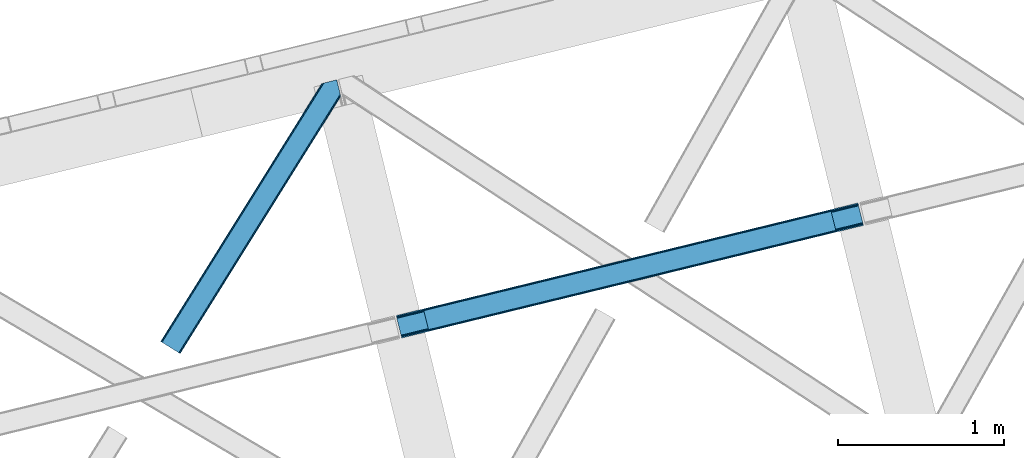
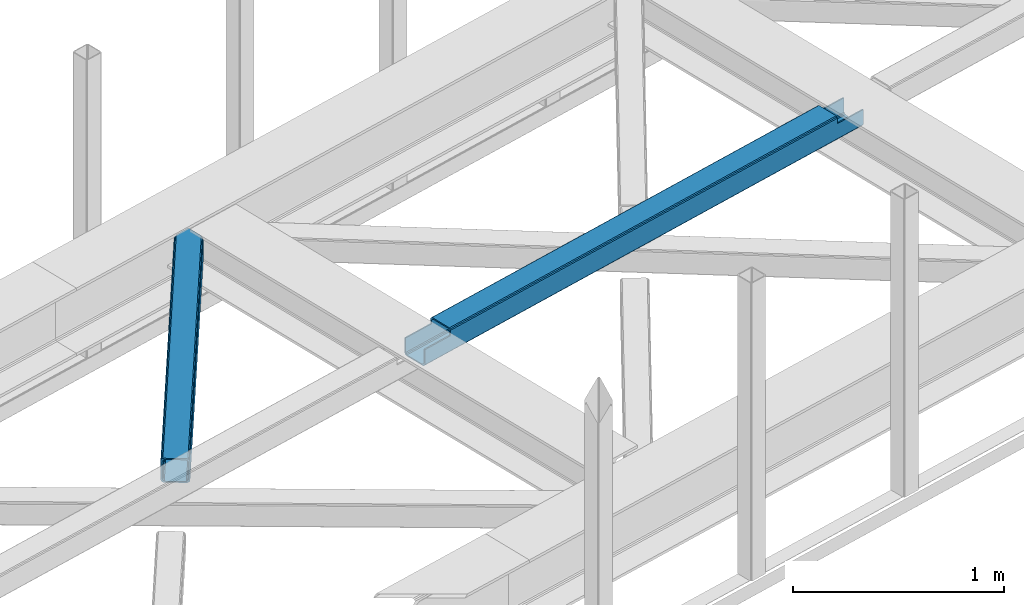
# One storey, part 53 of 67: 1 beam, 1 member.
"""IFC4 building model written with IfcOpenShell, lengths in millimetres."""

import ifcopenshell
import ifcopenshell.guid

model = None  # the IFC model being written
_history = None  # IfcOwnerHistory: only IFC2X3 demands one
_inside = {}  # id of a spatial element -> (the spatial element, [elements in it])
_under = {}  # id of a project, library or spatial element -> (it, [spatial elements below it])
_declared = {}  # id of a project -> (the project, [libraries it declares])
_typed = {}  # id of a type object -> (the type object, [elements of that type])
_made_of = {}  # id of a material, layer set ... -> (it, [elements and type objects made of it])


def new_model(schema):
    """Start an empty IFC model of exactly this schema.

    Asked for "IFC4X3", IfcOpenShell would pick the latest addendum, in which some entities
    have other attributes; the version numbers below select the first issue.
    IFC2X3 requires an IfcOwnerHistory on every rooted entity: one is made here for all.
    """
    global model, _history
    if schema == "IFC4X3":
        model = ifcopenshell.file(schema_version=(4, 3, 0, 0))
    else:
        model = ifcopenshell.file(schema=schema)
    _inside.clear()
    _under.clear()
    _declared.clear()
    _typed.clear()
    _made_of.clear()
    _history = None
    if model.schema == "IFC2X3":
        org = make("IfcOrganization", Name="unknown")
        user = make(
            "IfcPersonAndOrganization",
            ThePerson=make("IfcPerson", FamilyName="unknown"),
            TheOrganization=org,
        )
        app = make(
            "IfcApplication",
            ApplicationDeveloper=org,
            Version="unknown",
            ApplicationFullName="unknown",
            ApplicationIdentifier="unknown",
        )
        _history = make(
            "IfcOwnerHistory",
            OwningUser=user,
            OwningApplication=app,
            ChangeAction="ADDED",
            CreationDate=0,
        )
    return model


def make(cls, **values):
    """One entity of the class cls with the attributes given. An attribute that is None is left unset."""
    return model.create_entity(
        cls, **{name: value for name, value in values.items() if value is not None}
    )


def entity(cls, *values):
    """Any entity or typed value of the class cls, its attributes in the order of the schema. None: left unset."""
    e = model.create_entity(cls)
    for i, value in enumerate(values):
        if value is not None:
            e[i] = value
    return e


def rooted(cls, **values):
    """An entity with a GlobalId (a new one), such as an element, a storey or a relation."""
    return make(cls, GlobalId=ifcopenshell.guid.new(), OwnerHistory=_history, **values)


def si_unit(unit_type, name, prefix=None):
    """IfcSIUnit, for example si_unit("LENGTHUNIT", "METRE", prefix="MILLI")."""
    return make("IfcSIUnit", UnitType=unit_type, Prefix=prefix, Name=name)


def converted_unit(unit_type, name, factor, base, dimensions=None, offset=None):
    """IfcConversionBasedUnit, such as the inch: factor (a typed value) times the base unit."""
    return make(
        "IfcConversionBasedUnit"
        if offset is None
        else "IfcConversionBasedUnitWithOffset",
        ConversionOffset=offset,
        Dimensions=None
        if dimensions is None
        else entity("IfcDimensionalExponents", *dimensions),
        UnitType=unit_type,
        Name=name,
        ConversionFactor=make(
            "IfcMeasureWithUnit", ValueComponent=factor, UnitComponent=base
        ),
    )


def derived_unit(unit_type, elements):
    """IfcDerivedUnit: a product of units, each with its exponent."""
    return make(
        "IfcDerivedUnit",
        Elements=[
            make("IfcDerivedUnitElement", Unit=unit, Exponent=power)
            for unit, power in elements
        ],
        UnitType=unit_type,
    )


def assignment(units):
    """IfcUnitAssignment: the units of a project."""
    return None if units is None else make("IfcUnitAssignment", Units=units)


def point(xyz):
    """IfcCartesianPoint."""
    return None if xyz is None else make("IfcCartesianPoint", Coordinates=xyz)


def direction(xyz):
    """IfcDirection."""
    return None if xyz is None else make("IfcDirection", DirectionRatios=xyz)


def frame(location, z_axis=None, x_axis=None):
    """IfcAxis2Placement3D, a coordinate frame: its origin and axes. An axis left out is left unset."""
    return make(
        "IfcAxis2Placement3D",
        Location=point(location),
        Axis=direction(z_axis),
        RefDirection=direction(x_axis),
    )


def origin():
    """The frame at (0, 0, 0) with its axes left unset."""
    return frame((0.0, 0.0, 0.0))


def place(relative_to, where):
    """IfcLocalPlacement: puts the frame where relative to a parent placement (None: the world)."""
    return make(
        "IfcLocalPlacement", PlacementRelTo=relative_to, RelativePlacement=where
    )


def context(
    kind, dimensions, precision=None, world=None, true_north=None, identifier=None
):
    """IfcGeometricRepresentationContext, for example the 3D "Model" context."""
    return make(
        "IfcGeometricRepresentationContext",
        ContextIdentifier=identifier,
        ContextType=kind,
        CoordinateSpaceDimension=dimensions,
        Precision=precision,
        WorldCoordinateSystem=world,
        TrueNorth=true_north,
    )


def subcontext(parent, identifier, kind, view, scale=None):
    """IfcGeometricRepresentationSubContext, for example "Body" below "Model"."""
    return make(
        "IfcGeometricRepresentationSubContext",
        ContextIdentifier=identifier,
        ContextType=kind,
        ParentContext=parent,
        TargetScale=scale,
        TargetView=view,
    )


def project(units=None, contexts=None):
    """IfcProject with its units and contexts."""
    return rooted(
        "IfcProject",
        Name="project",
        RepresentationContexts=contexts,
        UnitsInContext=assignment(units),
    )


def spatial(cls, under=None, at=None, **own):
    """A site, building, storey or space (cls), placed at a placement, below another one or the project."""
    s = rooted(cls, ObjectPlacement=at, **own)
    if under is not None:
        _under.setdefault(under.id(), (under, []))[1].append(s)
    return s


def point_list(points):
    """IfcCartesianPointList2D or 3D."""
    cls = (
        "IfcCartesianPointList2D" if len(points[0]) == 2 else "IfcCartesianPointList3D"
    )
    return make(cls, CoordList=points)


def triangles(points, corners, closed=None, point_numbers=None):
    """IfcTriangulatedFaceSet: each triangle names its three corners, points numbered from 1."""
    return make(
        "IfcTriangulatedFaceSet",
        Coordinates=point_list(points),
        Closed=closed,
        CoordIndex=corners,
        PnIndex=point_numbers,
    )


def polygons(points, faces, closed=None, point_numbers=None):
    """IfcPolygonalFaceSet: a face is its outer loop, then its inner loops; points numbered from 1."""
    made = []
    for loops in faces:
        if len(loops) == 1:
            made.append(make("IfcIndexedPolygonalFace", CoordIndex=loops[0]))
        else:
            made.append(
                make(
                    "IfcIndexedPolygonalFaceWithVoids",
                    CoordIndex=loops[0],
                    InnerCoordIndices=loops[1:],
                )
            )
    return make(
        "IfcPolygonalFaceSet",
        Coordinates=point_list(points),
        Closed=closed,
        Faces=made,
        PnIndex=point_numbers,
    )


def shape(context_of_items, identifier, shape_type, items):
    """IfcShapeRepresentation: the items that make up one representation, for example the "Body"."""
    return make(
        "IfcShapeRepresentation",
        ContextOfItems=context_of_items,
        RepresentationIdentifier=identifier,
        RepresentationType=shape_type,
        Items=items,
    )


def material(Name=None, Category=None):
    """IfcMaterial."""
    return make("IfcMaterial", Name=Name, Category=Category)


def made_of(thing, what):
    """Note that an element or type object is made of a material, layer set ...; save() writes the relation."""
    if what is not None:
        _made_of.setdefault(what.id(), (what, []))[1].append(thing)
    return thing


def type_object(cls, material=None, **own):
    """A type object (cls), such as IfcWallType, which elements share."""
    return made_of(rooted(cls, **own), material)


def element(
    cls,
    number,
    at=None,
    inside=None,
    cuts=None,
    type_object=None,
    material=None,
    context=None,
    identifier="Body",
    shape_type=None,
    held_by="IfcProductDefinitionShape",
    body=None,
    shapes=None,
    **own,
):
    """One element of the class cls, such as IfcWall. Its Tag is "e" and its number.

    at: its placement. inside: the storey or other place that contains it. cuts: it is an
    opening in that element (IfcRelVoidsElement). A single representation is given by context,
    identifier, shape_type and body (its items); several are given by shapes. held_by: the class
    of the entity that holds the representations. save() writes the other relations.
    """
    e = rooted(cls, Tag="e%d" % number, ObjectPlacement=at, **own)
    if body is not None:
        shapes = [shape(context, identifier, shape_type, body)]
    if shapes is not None:
        e.Representation = make(held_by, Representations=shapes)
    if inside is not None:
        _inside.setdefault(inside.id(), (inside, []))[1].append(e)
    if cuts is not None:
        rooted(
            "IfcRelVoidsElement", RelatingBuildingElement=cuts, RelatedOpeningElement=e
        )
    if type_object is not None:
        _typed.setdefault(type_object.id(), (type_object, []))[1].append(e)
    return made_of(e, material)


def aggregate(whole, parts):
    """IfcRelAggregates: a whole, such as a stair, and the parts it consists of."""
    return rooted("IfcRelAggregates", RelatingObject=whole, RelatedObjects=parts)


def save(model, path):
    """Write the relations noted so far, then the file.

    IfcRelAggregates (storeys below a building ...), IfcRelContainedInSpatialStructure (elements
    in a storey), IfcRelDefinesByType, IfcRelAssociatesMaterial and IfcRelDeclares: one each for
    every whole, place, type object, material and project.
    """
    for whole, parts in _under.values():
        aggregate(whole, parts)
    for where, things in _inside.values():
        rooted(
            "IfcRelContainedInSpatialStructure",
            RelatedElements=things,
            RelatingStructure=where,
        )
    for kind, things in _typed.values():
        rooted("IfcRelDefinesByType", RelatedObjects=things, RelatingType=kind)
    for what, things in _made_of.values():
        rooted("IfcRelAssociatesMaterial", RelatedObjects=things, RelatingMaterial=what)
    for by, libraries in _declared.values():
        rooted("IfcRelDeclares", RelatingContext=by, RelatedDefinitions=libraries)
    model.write(path)


model = new_model("IFC4")

# Units and contexts
model_context = context("Model", 3, precision=0.01, world=origin(), true_north=direction((6.12303176911189e-17, 1.0)))
plan_context = context("Plan", 3, precision=0.01, world=origin(), true_north=direction((6.12303176911189e-17, 1.0)))
body_context = subcontext(model_context, "Body", "Model", "MODEL_VIEW")
ifc_project = project(units=[si_unit("LENGTHUNIT", "METRE", prefix="MILLI"), si_unit("AREAUNIT", "SQUARE_METRE"), si_unit("VOLUMEUNIT", "CUBIC_METRE"), converted_unit("PLANEANGLEUNIT", "DEGREE", entity("IfcRatioMeasure", 0.0174532925199433), si_unit("PLANEANGLEUNIT", "RADIAN"), dimensions=[0, 0, 0, 0, 0, 0, 0]), si_unit("MASSUNIT", "GRAM", prefix="KILO"), derived_unit("MASSDENSITYUNIT", [(si_unit("MASSUNIT", "GRAM", prefix="KILO"), 1), (si_unit("LENGTHUNIT", "METRE"), -3)]), derived_unit("MOMENTOFINERTIAUNIT", [(si_unit("LENGTHUNIT", "METRE"), 4)]), si_unit("TIMEUNIT", "SECOND"), si_unit("FREQUENCYUNIT", "HERTZ"), si_unit("THERMODYNAMICTEMPERATUREUNIT", "DEGREE_CELSIUS"), derived_unit("THERMALTRANSMITTANCEUNIT", [(si_unit("MASSUNIT", "GRAM", prefix="KILO"), 1), (si_unit("THERMODYNAMICTEMPERATUREUNIT", "KELVIN"), -1), (si_unit("TIMEUNIT", "SECOND"), -3)]), derived_unit("VOLUMETRICFLOWRATEUNIT", [(si_unit("LENGTHUNIT", "METRE"), 3), (si_unit("TIMEUNIT", "SECOND"), -1)]), derived_unit("MASSFLOWRATEUNIT", [(si_unit("MASSUNIT", "GRAM", prefix="KILO"), 1), (si_unit("TIMEUNIT", "SECOND"), -1)]), derived_unit("ROTATIONALFREQUENCYUNIT", [(si_unit("TIMEUNIT", "SECOND"), -1)]), si_unit("ELECTRICCURRENTUNIT", "AMPERE"), si_unit("ELECTRICVOLTAGEUNIT", "VOLT"), si_unit("POWERUNIT", "WATT"), si_unit("FORCEUNIT", "NEWTON", prefix="KILO"), si_unit("ILLUMINANCEUNIT", "LUX"), si_unit("LUMINOUSFLUXUNIT", "LUMEN"), si_unit("LUMINOUSINTENSITYUNIT", "CANDELA"), derived_unit("USERDEFINED", [(si_unit("MASSUNIT", "GRAM", prefix="KILO"), -1), (si_unit("LENGTHUNIT", "METRE"), -2), (si_unit("TIMEUNIT", "SECOND"), 3), (si_unit("LUMINOUSFLUXUNIT", "LUMEN"), 1)]), derived_unit("LINEARVELOCITYUNIT", [(si_unit("LENGTHUNIT", "METRE"), 1), (si_unit("TIMEUNIT", "SECOND"), -1)]), si_unit("PRESSUREUNIT", "PASCAL"), derived_unit("USERDEFINED", [(si_unit("LENGTHUNIT", "METRE"), -2), (si_unit("MASSUNIT", "GRAM", prefix="KILO"), 1), (si_unit("TIMEUNIT", "SECOND"), -2)]), derived_unit("LINEARFORCEUNIT", [(si_unit("MASSUNIT", "GRAM", prefix="KILO"), 1), (si_unit("LENGTHUNIT", "METRE"), 1), (si_unit("TIMEUNIT", "SECOND"), -2), (si_unit("LENGTHUNIT", "METRE"), -1)]), derived_unit("PLANARFORCEUNIT", [(si_unit("MASSUNIT", "GRAM", prefix="KILO"), 1), (si_unit("LENGTHUNIT", "METRE"), 1), (si_unit("TIMEUNIT", "SECOND"), -2), (si_unit("LENGTHUNIT", "METRE"), -2)])], contexts=[model_context, plan_context])

# Site, building, storey
site_placement = place(None, origin())
site = spatial("IfcSite", under=ifc_project, at=site_placement, CompositionType="ELEMENT")
building_placement = place(site_placement, origin())
building = spatial("IfcBuilding", under=site, at=building_placement, CompositionType="ELEMENT")
storey_placement = place(building_placement, frame((0.0, 0.0, 19800.0)))
storey = spatial("IfcBuildingStorey", under=building, at=storey_placement, CompositionType="ELEMENT", Elevation=19800.0)

# Beam
ifc_material = material(Name="Metal painted (White)")
beam_type = type_object("IfcBeamType", PredefinedType="BEAM")
beam_placement = place(storey_placement, frame((-11387.6664758472, 16364.0782857398, 3967.02022389142)))
element("IfcBeam", 1, at=beam_placement, inside=storey, type_object=beam_type, material=ifc_material, ObjectType="Steel Beam", PredefinedType="BEAM", context=body_context, shape_type="Tessellation", body=[
    polygons([(31.1823923917571, 8.09507685196108, 17.8030399336114), (31.4978703677273, 6.80086440699434, 24.4999999999988), (2817.90917311746, 686.018099103278, 24.4999999999988), (2817.59369514149, 687.312311548247, 17.8030399336114), (30.2839871259056, 11.7806820741864, 12.1256313292298), (2816.69528987564, 690.997916770472, 12.1256313292298), (28.9394286278213, 17.2965800886753, 8.33210818105214), (2815.35073137756, 696.513814784959, 8.33210818105214), (27.3534137403861, 23.8030254244661, 7.00000000000274), (2813.76471649012, 703.020260120752, 7.00000000000274), (4.21622439083043, 118.720708051134, 8.33210818105214), (5.80223927826556, 112.214262715343, 7.00000000000274), (2792.213542028, 791.431497411626, 7.00000000000274), (2790.62752714057, 797.937942747419, 8.33210818105214), (2.87166589274824, 124.236606065618, 12.1256313292342), (2789.28296864248, 803.453840761904, 12.1256313292342), (1.9732606268946, 127.922211287848, 17.8030399336114), (2788.38456337663, 807.139445984131, 17.8030399336114), (1.65778265094818, 129.216423732819, 24.4999999999988), (2788.06908540067, 808.433658429104, 24.4999999999988), (33.1556530186734, 6.49720277579036e-12, 17.5000000000004), (33.1556530186734, 6.49720277579036e-12, 99.499999999999), (31.4978703677403, 6.80086440699434, 99.499999999999), (1.65778265095251, 129.216423732821, 99.499999999999), (2.38230768445646e-11, 136.017288139815, 99.499999999999), (2.59888111031614e-11, 136.017288139815, 17.5000000000004), (0.315477975985408, 134.723075694844, 10.803039933613), (1.21388324183688, 131.037470472619, 5.12563132923143), (2.55844173992124, 125.52157245813, 1.33210818105373), (4.14445662735637, 119.015127122339, 0.0), (29.011196391343, 17.0021610174826, 0.0), (30.5972112787781, 10.4957156816896, 1.33210818105373), (31.9417697768603, 4.97981766720068, 5.12563132923576), (32.8401750427139, 1.29421244497757, 10.803039933613), (2786.41130274975, 815.234522836097, 17.5000000000004), (2786.41130274974, 815.234522836097, 99.499999999999), (2788.06908540068, 808.433658429104, 99.499999999999), (2817.90917311746, 686.01809910328, 99.499999999999), (2819.56695576839, 679.217234696288, 99.499999999999), (2819.5669557684, 679.217234696288, 17.5000000000004), (2819.25147779244, 680.511447141259, 10.803039933613), (2818.35307252658, 684.197052363484, 5.12563132923576), (2817.0085140285, 689.712950377973, 1.33210818105373), (2815.42249914106, 696.219395713764, 0.0), (2790.55575937708, 798.23236181862, 0.0), (2788.96974448964, 804.738807154413, 1.33210818105373), (2787.62518599156, 810.254705168902, 5.12563132923143), (2786.72678072571, 813.940310391125, 10.803039933613), (2653.72536552979, 645.996559503588, 115.5000123926), (2653.78173361466, 646.010298722204, 100.117303289864), (2654.68842734968, 646.231315480896, 99.499999999999), (194.718606580794, 46.5876811586757, 99.5063429816656), (195.631369831915, 46.810141494503, 100.117301735448), (195.690168193622, 46.824474122359, 115.5), (2656.34621000061, 639.430451073908, 99.499999999999), (2655.43964990836, 639.209466900397, 100.117303484932), (2655.38006714068, 639.194943868054, 122.500007895425), (197.345360928049, 40.0229783796023, 122.500002534479), (197.338587096739, 40.0213271441479, 100.500009163303), (196.748205195722, 39.8773799905087, 99.5697919021647), (2624.84834918759, 768.646841677419, 99.5063429816656), (2623.93924032811, 768.4252715147, 100.117299778624), (2623.88287224324, 768.411532296082, 115.50000888136), (165.850080476841, 169.240033448183, 115.5), (165.84046220334, 169.237688832046, 100.50000941238), (165.250325295035, 169.093836777333, 99.5761204674868), (2622.81875057266, 775.357142845586, 99.5697919021647), (163.220745767765, 175.804071762184, 99.499999999999), (164.133244938514, 176.026503182399, 100.117301984524), (164.18943998763, 176.04020120897, 122.500002796667), (2622.22174126673, 775.211580304167, 122.500003994045), (2622.23184455557, 775.214043718734, 100.500018741102), (2622.53385542111, 773.916547681999, 129.196959150505), (2623.4271909467, 770.229706340309, 134.874360354937), (2624.76848195077, 764.7130116355, 138.667878733795), (2626.35352903677, 758.206330327425, 139.999985502214), (2651.2242780837, 656.194341778115, 139.999991354279), (2652.81177220129, 649.688257112712, 138.667885332354), (2654.16003176172, 644.173261502483, 134.874367586349), (2655.06379646893, 640.488963035532, 129.196966804773), (2653.41217589809, 647.2913298996, 122.196975799125), (2652.50841119088, 650.975628366557, 127.874376580702), (2651.16015163044, 656.490623976784, 131.667894326702), (2649.57265751286, 662.996708642187, 133.000000348631), (2628.01800833885, 751.407098718257, 132.999995276841), (2626.43296125285, 757.913780026333, 131.667888508414), (2625.09167024878, 763.43047473114, 127.874370129564), (2624.19833472319, 767.117316072832, 122.196968925133), (164.878528418698, 169.003207355194, 99.499999999999), (193.131726453727, 57.3201898040399, 131.667891818946), (191.545711566292, 63.8266351398329, 133.0), (194.476284951809, 51.804291789551, 127.874368670764), (195.374690217663, 48.1186865673279, 122.196960066391), (169.994537104169, 152.237872430707, 133.0), (166.165558452801, 167.945821003215, 122.196960066391), (167.063963718652, 164.260215780991, 127.874368670764), (168.408522216736, 158.744317766502, 131.667891818946), (197.031411944073, 41.3175635421181, 129.196961104604), (196.136488323068, 45.0040174739024, 134.874366301861), (194.794244157317, 50.5204796458773, 138.667887185257), (193.209023953586, 57.0271186992037, 139.999994588639), (168.341882306943, 159.039986838394, 139.999994981919), (166.755021471191, 165.546225960038, 138.667887628704), (165.408105180735, 171.061549222932, 134.874366787843), (164.506189230969, 174.746298656828, 129.196961619)], [[[1, 2, 3, 4]], [[5, 1, 4, 6]], [[7, 5, 6, 8]], [[9, 7, 8, 10]], [[11, 12, 13, 14]], [[15, 11, 14, 16]], [[17, 15, 16, 18]], [[19, 17, 18, 20]], [[12, 9, 10, 13]], [[21, 22, 23, 2, 1, 5, 7, 9, 12, 11, 15, 17, 19, 24, 25, 26, 27, 28, 29, 30, 31, 32, 33, 34]], [[35, 36, 37, 20, 18, 16, 14, 13, 10, 8, 6, 4, 3, 38, 39, 40, 41, 42, 43, 44, 45, 46, 47, 48]], [[49, 50, 51, 38, 3, 2, 23, 52, 53, 54]], [[55, 39, 38, 51]], [[39, 55, 56, 57, 58, 59, 60, 22, 21, 40]], [[32, 31, 44, 43]], [[33, 32, 43, 42]], [[34, 33, 42, 41]], [[21, 34, 41, 40]], [[31, 30, 45, 44]], [[27, 26, 35, 48]], [[28, 27, 48, 47]], [[29, 28, 47, 46]], [[30, 29, 46, 45]], [[20, 37, 61, 62, 63, 64, 65, 66, 24, 19]], [[67, 36, 35, 26, 25, 68, 69, 70, 71, 72]], [[36, 67, 61, 37]], [[72, 71, 73, 74, 75, 76, 77, 78, 79, 80, 57, 56, 50, 49, 81, 82, 83, 84, 85, 86, 87, 88, 63, 62]], [[60, 52, 23, 22]], [[25, 24, 89, 68]], [[90, 91, 84, 83]], [[92, 90, 83, 82]], [[93, 92, 82, 81]], [[54, 93, 81, 49]], [[94, 85, 84, 91]], [[95, 64, 63, 88]], [[96, 95, 88, 87]], [[97, 96, 87, 86]], [[94, 97, 86, 85]], [[65, 64, 95, 96, 97, 94, 91, 90, 92, 93, 54, 53, 59, 58, 98, 99, 100, 101, 102, 103, 104, 105, 70, 69]], [[98, 58, 57, 80]], [[99, 98, 80, 79]], [[100, 99, 79, 78]], [[101, 100, 78, 77]], [[77, 76, 102, 101]], [[103, 102, 76, 75]], [[104, 103, 75, 74]], [[105, 104, 74, 73]], [[70, 105, 73, 71]]], closed=False),
])

# Member
member_type = type_object("IfcMemberType", PredefinedType="BRACE")
member_placement = place(storey_placement, frame((-12809.6402069092, 16269.3394958496, 3822.99993896484)))
element("IfcMember", 2, at=member_placement, inside=storey, type_object=member_type, ObjectType="Steel Horizontal Brace", PredefinedType="BRACE", context=body_context, shape_type="Tessellation", body=[
    triangles([(933.019793701173, 1535.69114685059, 0.0), (967.779299926759, 1393.09054870606, 0.0), (14.8479309082031, 64.8692962646492, 0.0), (103.918075561523, 9.26687622070313, 0.0), (928.802609252929, 1552.99009094238, 5.49966430664063), (928.943298339844, 1552.41570739746, 5.208984375), (930.802487182616, 1544.78594055176, 1.33247680664135), (971.996484375, 1375.79160461426, 5.49966430664063), (971.856958007813, 1376.36598815918, 5.208984375), (969.996606445313, 1383.99575500488, 1.33247680664135), (972.211587524414, 1375.53696899414, 5.8531311035149), (972.422039794921, 1375.28233337402, 6.20659790039281), (928.915393066407, 1553.56912536621, 5.74383544921875), (972.724346923827, 1375.53696899414, 6.35310058593677), (929.030502319336, 1554.17606506348, 5.9996337890625), (973.025491333008, 1375.79160461426, 6.49960327148438), (929.145611572265, 1554.78300476074, 6.25543212890625), (929.253744506836, 1555.36087646485, 6.49960327148438), (4.3520599365238, 71.4223846435543, 5.12526855468968), (1.13365173339844, 73.4315643310547, 10.8039916992202), (973.359191894531, 1630.84231567383, 10.8039916992202), (976.915951538085, 1631.70854187012, 6.49960327148438), (9.16804504394531, 68.4155914306648, 1.33247680664135), (971.506979370117, 1630.3900177002, 17.5012573242202), (0.0, 74.1361724853523, 17.5012573242202), (1081.10028991699, 1548.91592102051, 6.49960327148438), (1056.20762329101, 1651.03643188476, 6.49960327148438), (971.506979370117, 1630.3900177002, 122.499499511719), (0.0, 74.1361724853523, 122.499499511719), (973.359191894531, 1630.84231567383, 129.196765136719), (1.13365173339844, 73.4315643310547, 129.196765136719), (978.636776733398, 1632.12828369141, 134.87548828125), (4.3520599365238, 71.4223846435543, 134.87548828125), (986.530480957032, 1634.05258483887, 138.668280029298), (9.16804504394531, 68.4155914306648, 138.668280029298), (995.83921508789, 1636.32105102539, 140.00075683594), (14.8479309082031, 64.8692962646492, 140.00075683594), (118.762518310547, 0.0, 17.5012573242202), (117.632354736328, 0.705770874023074, 10.8039916992202), (1085.14190368652, 1551.24949951172, 10.9783996582046), (1087.41618347168, 1552.56337280274, 13.4991760253906), (109.597961425781, 5.7205810546875, 1.33247680664135), (114.413946533203, 2.71378784179615, 5.12526855468968), (1087.56966247559, 1551.93434143066, 17.5012573242202), (1081.77583007812, 1575.70149536133, 140.00075683594), (1063.00837097168, 1652.69447021484, 140.00075683594), (103.918075561523, 9.26687622070313, 140.00075683594), (1083.99313659668, 1566.60553894043, 138.668280029298), (109.597961425781, 5.7205810546875, 138.668280029298), (1085.8720916748, 1558.8955444336, 134.87548828125), (114.413946533203, 2.71378784179615, 134.87548828125), (1087.12782897949, 1553.7435333252, 129.196765136719), (117.632354736328, 0.705770874023074, 129.196765136719), (1087.56966247559, 1551.93434143066, 122.499499511719), (118.762518310547, 0.0, 122.499499511719), (1082.53973693848, 1566.77297058106, 12.1248413085959), (1083.96406860352, 1566.72297363281, 13.4991760253906), (1077.85048828125, 1569.98440246582, 8.3320495605476), (1074.64952087402, 1577.50022277832, 6.99957275390625), (1056.69596557617, 1651.1561920166, 6.99957275390625), (1005.57234191895, 1638.6941619873, 6.99957275390625), (20.7836151123047, 61.1613830566403, 6.99957275390625), (97.9789031982418, 12.9736267089847, 6.99957275390625), (108.474774169921, 6.42053833007776, 12.1248413085959), (111.693182373047, 4.4113586425774, 17.8035644531265), (1084.81052856445, 1563.24992980957, 17.8035644531265), (103.6587890625, 9.42733154296911, 8.3320495605476), (1085.25236206055, 1561.44073791504, 24.5008300781265), (112.822183227539, 3.70675048828161, 24.5008300781265), (983.092318725587, 1633.21426391602, 17.8035644531265), (981.240106201172, 1632.76312866211, 24.5008300781265), (7.06817321777271, 69.7236511230476, 17.8035644531265), (5.93917236328161, 70.4294219970707, 24.5008300781265), (988.369903564453, 1634.50139465332, 12.1248413085959), (10.2865814208981, 67.7144714355472, 12.1248413085959), (996.263607788085, 1636.42569580078, 8.3320495605476), (15.1025665283196, 64.7088409423832, 8.3320495605476), (981.240106201172, 1632.76312866211, 115.499926757813), (5.93917236328161, 70.4294219970707, 115.499926757813), (996.263607788085, 1636.42569580078, 131.668707275392), (1005.57234191895, 1638.6941619873, 133.001184082033), (1063.00837097168, 1652.69447021484, 133.001184082033), (988.369903564453, 1634.50139465332, 127.873590087893), (983.092318725587, 1633.21426391602, 122.197192382813), (20.7836151123047, 61.1613830566403, 133.001184082033), (15.1025665283196, 64.7088409423832, 131.668707275392), (10.2865814208981, 67.7144714355472, 127.873590087893), (7.06817321777271, 69.7236511230476, 122.197192382813), (108.474774169921, 6.42053833007776, 127.873590087893), (111.693182373047, 4.4113586425774, 122.197192382813), (112.822183227539, 3.70675048828161, 115.499926757813), (97.9789031982418, 12.9736267089847, 133.001184082033), (103.6587890625, 9.42733154296911, 131.668707275392), (1085.25236206055, 1561.44073791504, 115.499926757813), (1084.81052856445, 1563.24992980957, 122.197192382813), (1083.55479125976, 1568.40194091797, 127.873590087893), (1081.67583618164, 1576.11309814453, 131.668707275392), (1079.45852966309, 1585.2078918457, 133.001184082033)], [[1, 2, 3], [4, 3, 2], [1, 5, 2], [6, 5, 1], [1, 7, 6], [2, 5, 8], [8, 9, 2], [10, 2, 9], [11, 8, 5], [12, 11, 13], [14, 12, 15], [16, 14, 17], [17, 18, 16], [15, 17, 14], [13, 15, 12], [5, 13, 11], [17, 19, 18], [19, 17, 15], [13, 19, 15], [19, 13, 5], [5, 6, 19], [20, 21, 18], [18, 19, 20], [21, 22, 18], [19, 6, 7], [7, 1, 23], [3, 23, 1], [7, 23, 19], [24, 21, 20], [20, 25, 24], [18, 26, 16], [26, 18, 22], [27, 26, 22], [28, 24, 25], [25, 29, 28], [30, 28, 31], [29, 31, 28], [32, 30, 33], [31, 33, 30], [34, 32, 35], [33, 35, 32], [36, 34, 37], [35, 37, 34], [38, 39, 40], [40, 41, 38], [42, 10, 9], [39, 12, 16], [16, 40, 39], [16, 26, 40], [9, 39, 43], [9, 12, 39], [9, 43, 42], [2, 10, 4], [42, 4, 10], [41, 44, 38], [45, 36, 37], [36, 45, 46], [37, 47, 45], [48, 45, 47], [47, 49, 48], [50, 48, 49], [49, 51, 50], [52, 50, 51], [51, 53, 52], [54, 52, 53], [53, 55, 54], [44, 54, 55], [55, 38, 44], [56, 40, 26], [41, 40, 56], [56, 57, 41], [58, 26, 59], [26, 58, 56], [60, 59, 26], [59, 61, 62], [61, 59, 60], [62, 63, 59], [64, 65, 66], [66, 57, 64], [58, 59, 63], [63, 67, 58], [56, 58, 67], [67, 64, 56], [57, 56, 64], [68, 66, 65], [65, 69, 68], [70, 71, 72], [73, 72, 71], [74, 70, 75], [72, 75, 70], [76, 74, 77], [75, 77, 74], [61, 76, 62], [77, 62, 76], [71, 78, 73], [79, 73, 78], [34, 36, 80], [46, 81, 36], [81, 46, 82], [81, 80, 36], [83, 34, 80], [83, 32, 34], [32, 84, 30], [84, 32, 83], [28, 84, 78], [84, 28, 30], [61, 22, 76], [70, 74, 22], [74, 76, 22], [61, 60, 22], [71, 70, 24], [21, 24, 70], [28, 71, 24], [71, 28, 78], [70, 22, 21], [80, 81, 85], [85, 86, 80], [83, 80, 86], [86, 87, 83], [84, 83, 87], [87, 88, 84], [78, 84, 88], [88, 79, 78], [53, 89, 90], [91, 38, 55], [53, 90, 55], [53, 51, 89], [90, 91, 55], [89, 51, 49], [92, 47, 37], [47, 93, 49], [93, 47, 92], [93, 89, 49], [39, 64, 43], [69, 38, 91], [38, 65, 39], [65, 38, 69], [39, 65, 64], [4, 63, 3], [42, 43, 64], [64, 67, 42], [67, 63, 4], [4, 42, 67], [87, 35, 33], [37, 85, 92], [37, 86, 85], [86, 37, 35], [87, 86, 35], [79, 29, 25], [31, 88, 87], [33, 31, 87], [88, 31, 29], [79, 88, 29], [23, 75, 19], [3, 63, 62], [62, 77, 3], [77, 75, 23], [23, 3, 77], [20, 19, 75], [25, 73, 79], [72, 25, 20], [25, 72, 73], [72, 20, 75], [66, 41, 57], [54, 44, 68], [44, 66, 68], [68, 94, 54], [44, 41, 66], [95, 54, 94], [52, 54, 95], [50, 95, 96], [95, 50, 52], [96, 48, 50], [97, 48, 96], [97, 98, 45], [97, 45, 48], [98, 46, 45], [98, 82, 46], [81, 98, 85], [81, 82, 98], [92, 85, 98], [95, 94, 90], [91, 90, 94], [96, 95, 89], [90, 89, 95], [97, 96, 93], [89, 93, 96], [98, 97, 92], [93, 92, 97], [94, 68, 91], [69, 91, 68]]),
])

save(model, "model.ifc")
